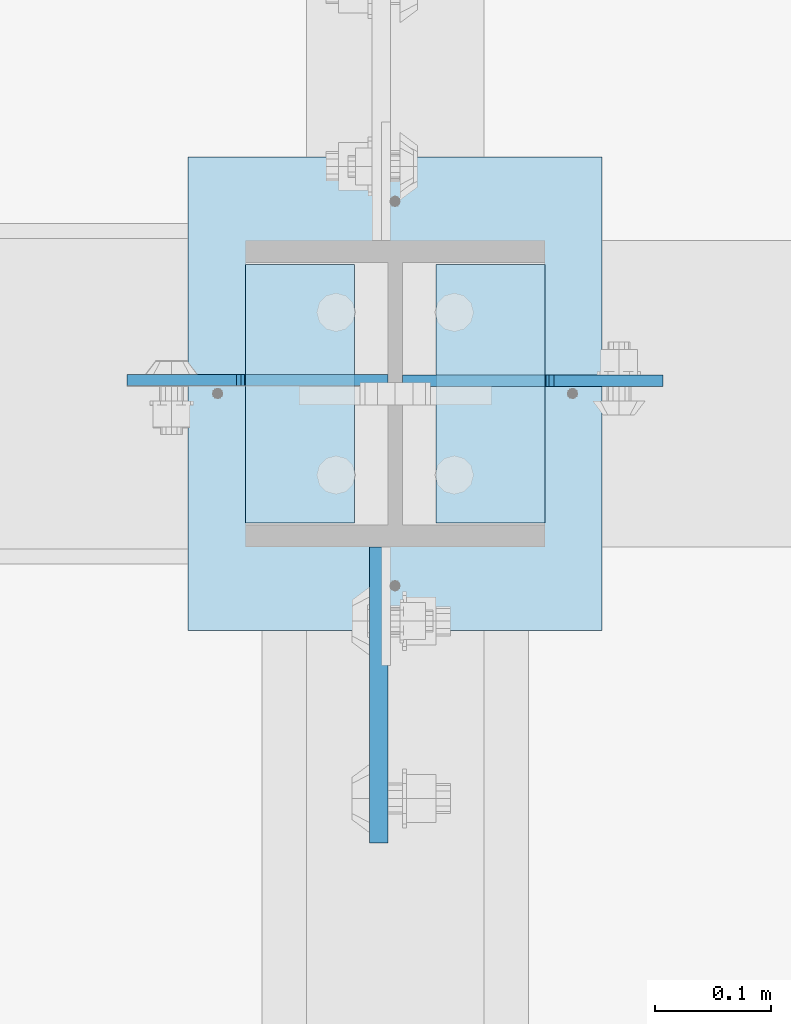
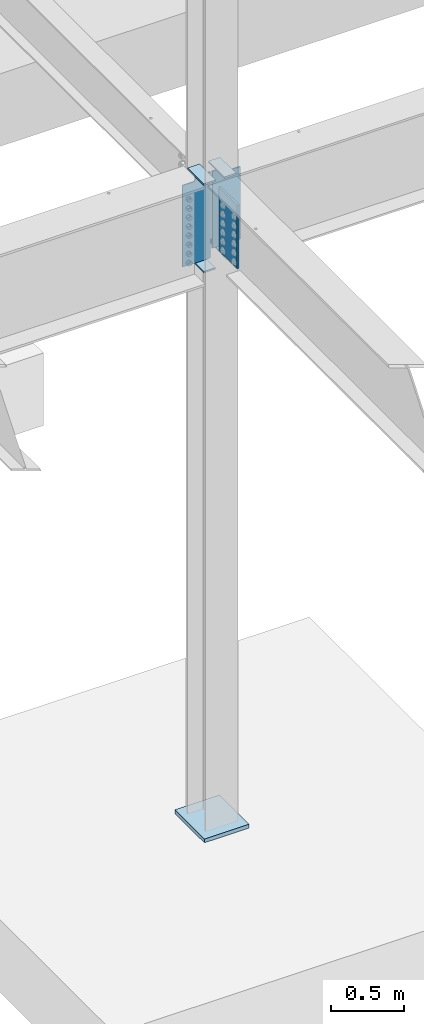
# One storey, part 1530 of 1763: 8 plates, 1 element without a shape of its own.
"""IFC2X3 building model written with IfcOpenShell, lengths in millimetres."""

import ifcopenshell
import ifcopenshell.guid

model = None  # the IFC model being written
_history = None  # IfcOwnerHistory: only IFC2X3 demands one
_inside = {}  # id of a spatial element -> (the spatial element, [elements in it])
_under = {}  # id of a project, library or spatial element -> (it, [spatial elements below it])
_declared = {}  # id of a project -> (the project, [libraries it declares])
_typed = {}  # id of a type object -> (the type object, [elements of that type])
_made_of = {}  # id of a material, layer set ... -> (it, [elements and type objects made of it])


def new_model(schema):
    """Start an empty IFC model of exactly this schema.

    Asked for "IFC4X3", IfcOpenShell would pick the latest addendum, in which some entities
    have other attributes; the version numbers below select the first issue.
    IFC2X3 requires an IfcOwnerHistory on every rooted entity: one is made here for all.
    """
    global model, _history
    if schema == "IFC4X3":
        model = ifcopenshell.file(schema_version=(4, 3, 0, 0))
    else:
        model = ifcopenshell.file(schema=schema)
    _inside.clear()
    _under.clear()
    _declared.clear()
    _typed.clear()
    _made_of.clear()
    _history = None
    if model.schema == "IFC2X3":
        org = make("IfcOrganization", Name="unknown")
        user = make(
            "IfcPersonAndOrganization",
            ThePerson=make("IfcPerson", FamilyName="unknown"),
            TheOrganization=org,
        )
        app = make(
            "IfcApplication",
            ApplicationDeveloper=org,
            Version="unknown",
            ApplicationFullName="unknown",
            ApplicationIdentifier="unknown",
        )
        _history = make(
            "IfcOwnerHistory",
            OwningUser=user,
            OwningApplication=app,
            ChangeAction="ADDED",
            CreationDate=0,
        )
    return model


def make(cls, **values):
    """One entity of the class cls with the attributes given. An attribute that is None is left unset."""
    return model.create_entity(
        cls, **{name: value for name, value in values.items() if value is not None}
    )


def rooted(cls, **values):
    """An entity with a GlobalId (a new one), such as an element, a storey or a relation."""
    return make(cls, GlobalId=ifcopenshell.guid.new(), OwnerHistory=_history, **values)


def si_unit(unit_type, name, prefix=None):
    """IfcSIUnit, for example si_unit("LENGTHUNIT", "METRE", prefix="MILLI")."""
    return make("IfcSIUnit", UnitType=unit_type, Prefix=prefix, Name=name)


def assignment(units):
    """IfcUnitAssignment: the units of a project."""
    return None if units is None else make("IfcUnitAssignment", Units=units)


def point(xyz):
    """IfcCartesianPoint."""
    return None if xyz is None else make("IfcCartesianPoint", Coordinates=xyz)


def direction(xyz):
    """IfcDirection."""
    return None if xyz is None else make("IfcDirection", DirectionRatios=xyz)


def frame(location, z_axis=None, x_axis=None):
    """IfcAxis2Placement3D, a coordinate frame: its origin and axes. An axis left out is left unset."""
    return make(
        "IfcAxis2Placement3D",
        Location=point(location),
        Axis=direction(z_axis),
        RefDirection=direction(x_axis),
    )


def origin_with_axes():
    """The frame at (0, 0, 0) with the z axis (0, 0, 1) and the x axis (1, 0, 0) written out."""
    return frame((0.0, 0.0, 0.0), z_axis=(0.0, 0.0, 1.0), x_axis=(1.0, 0.0, 0.0))


def place(relative_to, where):
    """IfcLocalPlacement: puts the frame where relative to a parent placement (None: the world)."""
    return make(
        "IfcLocalPlacement", PlacementRelTo=relative_to, RelativePlacement=where
    )


def context(
    kind, dimensions, precision=None, world=None, true_north=None, identifier=None
):
    """IfcGeometricRepresentationContext, for example the 3D "Model" context."""
    return make(
        "IfcGeometricRepresentationContext",
        ContextIdentifier=identifier,
        ContextType=kind,
        CoordinateSpaceDimension=dimensions,
        Precision=precision,
        WorldCoordinateSystem=world,
        TrueNorth=true_north,
    )


def subcontext(parent, identifier, kind, view, scale=None):
    """IfcGeometricRepresentationSubContext, for example "Body" below "Model"."""
    return make(
        "IfcGeometricRepresentationSubContext",
        ContextIdentifier=identifier,
        ContextType=kind,
        ParentContext=parent,
        TargetScale=scale,
        TargetView=view,
    )


def project(units=None, contexts=None):
    """IfcProject with its units and contexts."""
    return rooted(
        "IfcProject",
        Name="project",
        RepresentationContexts=contexts,
        UnitsInContext=assignment(units),
    )


def spatial(cls, under=None, at=None, **own):
    """A site, building, storey or space (cls), placed at a placement, below another one or the project."""
    s = rooted(cls, ObjectPlacement=at, **own)
    if under is not None:
        _under.setdefault(under.id(), (under, []))[1].append(s)
    return s


def faces_of(points, faces, orient=None, outer=None):
    """IfcFace entities. A face is a list of loops; a loop is a list of indices into points, from 0.

    orient and outer hold one flag for each loop. By default every Orientation is true, the
    first loop of a face is its IfcFaceOuterBound and the others are IfcFaceBound.
    """
    made = []
    for i, loops in enumerate(faces):
        bounds = []
        for j, loop in enumerate(loops):
            is_outer = j == 0 if outer is None else outer[i][j]
            bounds.append(
                make(
                    "IfcFaceOuterBound" if is_outer else "IfcFaceBound",
                    Bound=make("IfcPolyLoop", Polygon=[points[k] for k in loop]),
                    Orientation=True if orient is None else orient[i][j],
                )
            )
        made.append(make("IfcFace", Bounds=bounds))
    return made


def faceted_brep(points, faces, orient=None, outer=None, voids=None):
    """IfcFacetedBrep: a solid bounded by flat faces; with voids (closed shells), ...WithVoids."""
    shared = [point(p) for p in points]
    hull = make("IfcClosedShell", CfsFaces=faces_of(shared, faces, orient, outer))
    if voids is None:
        return make("IfcFacetedBrep", Outer=hull)
    return make(
        "IfcFacetedBrepWithVoids",
        Outer=hull,
        Voids=[
            make(cls, CfsFaces=faces_of(shared, fs, o, b)) for cls, fs, o, b in voids
        ],
    )


def shape(context_of_items, identifier, shape_type, items):
    """IfcShapeRepresentation: the items that make up one representation, for example the "Body"."""
    return make(
        "IfcShapeRepresentation",
        ContextOfItems=context_of_items,
        RepresentationIdentifier=identifier,
        RepresentationType=shape_type,
        Items=items,
    )


def material(Name=None, Category=None):
    """IfcMaterial."""
    return make("IfcMaterial", Name=Name, Category=Category)


def made_of(thing, what):
    """Note that an element or type object is made of a material, layer set ...; save() writes the relation."""
    if what is not None:
        _made_of.setdefault(what.id(), (what, []))[1].append(thing)
    return thing


def type_object(cls, material=None, **own):
    """A type object (cls), such as IfcWallType, which elements share."""
    return made_of(rooted(cls, **own), material)


def element(
    cls,
    number,
    at=None,
    inside=None,
    cuts=None,
    type_object=None,
    material=None,
    context=None,
    identifier="Body",
    shape_type=None,
    held_by="IfcProductDefinitionShape",
    body=None,
    shapes=None,
    **own,
):
    """One element of the class cls, such as IfcWall. Its Tag is "e" and its number.

    at: its placement. inside: the storey or other place that contains it. cuts: it is an
    opening in that element (IfcRelVoidsElement). A single representation is given by context,
    identifier, shape_type and body (its items); several are given by shapes. held_by: the class
    of the entity that holds the representations. save() writes the other relations.
    """
    e = rooted(cls, Tag="e%d" % number, ObjectPlacement=at, **own)
    if body is not None:
        shapes = [shape(context, identifier, shape_type, body)]
    if shapes is not None:
        e.Representation = make(held_by, Representations=shapes)
    if inside is not None:
        _inside.setdefault(inside.id(), (inside, []))[1].append(e)
    if cuts is not None:
        rooted(
            "IfcRelVoidsElement", RelatingBuildingElement=cuts, RelatedOpeningElement=e
        )
    if type_object is not None:
        _typed.setdefault(type_object.id(), (type_object, []))[1].append(e)
    return made_of(e, material)


def aggregate(whole, parts):
    """IfcRelAggregates: a whole, such as a stair, and the parts it consists of."""
    return rooted("IfcRelAggregates", RelatingObject=whole, RelatedObjects=parts)


def save(model, path):
    """Write the relations noted so far, then the file.

    IfcRelAggregates (storeys below a building ...), IfcRelContainedInSpatialStructure (elements
    in a storey), IfcRelDefinesByType, IfcRelAssociatesMaterial and IfcRelDeclares: one each for
    every whole, place, type object, material and project.
    """
    for whole, parts in _under.values():
        aggregate(whole, parts)
    for where, things in _inside.values():
        rooted(
            "IfcRelContainedInSpatialStructure",
            RelatedElements=things,
            RelatingStructure=where,
        )
    for kind, things in _typed.values():
        rooted("IfcRelDefinesByType", RelatedObjects=things, RelatingType=kind)
    for what, things in _made_of.values():
        rooted("IfcRelAssociatesMaterial", RelatedObjects=things, RelatingMaterial=what)
    for by, libraries in _declared.values():
        rooted("IfcRelDeclares", RelatingContext=by, RelatedDefinitions=libraries)
    model.write(path)


model = new_model("IFC2X3")

# Units and contexts
model_context = context("Model", 3, precision=1e-05, world=origin_with_axes())
body_context = subcontext(model_context, "Body", "Model", "MODEL_VIEW")
ifc_project = project(units=[si_unit("LENGTHUNIT", "METRE", prefix="MILLI"), si_unit("AREAUNIT", "SQUARE_METRE"), si_unit("VOLUMEUNIT", "CUBIC_METRE"), si_unit("MASSUNIT", "GRAM", prefix="KILO"), si_unit("TIMEUNIT", "SECOND"), si_unit("PLANEANGLEUNIT", "RADIAN"), si_unit("SOLIDANGLEUNIT", "STERADIAN"), si_unit("THERMODYNAMICTEMPERATUREUNIT", "DEGREE_CELSIUS"), si_unit("LUMINOUSINTENSITYUNIT", "LUMEN")], contexts=[model_context])

# Site, building, storey
site_placement = place(None, origin_with_axes())
site = spatial("IfcSite", under=ifc_project, at=site_placement, CompositionType="ELEMENT")
building_placement = place(site_placement, origin_with_axes())
building = spatial("IfcBuilding", under=site, at=building_placement, Name="Undefined", CompositionType="ELEMENT")
storey_placement = place(building_placement, origin_with_axes())
storey = spatial("IfcBuildingStorey", under=building, at=storey_placement, Name="Undefined", CompositionType="ELEMENT", Elevation=0.0)

# Assembly, plates
assembly_placement = place(storey_placement, origin_with_axes())
assembly = element("IfcElementAssembly", 1, at=assembly_placement, inside=storey, Name="COLUMN", AssemblyPlace="NOTDEFINED", PredefinedType="RIGID_FRAME")
ifc_material_1 = material(Name="STEEL/A36")
plate_type_1 = type_object("IfcPlateType", PredefinedType="NOTDEFINED")
plate_1_placement = place(assembly_placement, frame((-72619.6247736983, 44916.725, 4451.34997558594), z_axis=(0.0, -1.0, 0.0), x_axis=(1.0, 0.0, 0.0)))
plate_1 = element("IfcPlate", 2, at=plate_1_placement, type_object=plate_type_1, material=ifc_material_1, Name="PLATE", context=body_context, shape_type="Brep", body=[
    faceted_brep([(0.0, -6.34999999999491, 1.45519152283669e-11), (0.0, -6.35000000000036, 222.25), (0.0, 6.35000000000036, 222.25), (0.0, 6.34999999999491, -2.91038304567337e-11), (93.6624984741211, -6.35000000000036, 222.25), (93.6624984741211, 6.35000000000036, 222.25), (93.6624984741211, -6.35000000000036, 0.0), (93.6624984741211, 6.35000000000036, 0.0)], [[[0, 1, 2, 3]], [[1, 4, 5, 2]], [[4, 6, 7, 5]], [[6, 0, 3, 7]], [[5, 7, 3, 2]], [[6, 4, 1, 0]]]),
])
plate_2_placement = place(assembly_placement, frame((-72619.6247736983, 44916.725, 5187.95), z_axis=(0.0, -1.0, 0.0), x_axis=(1.0, 0.0, 0.0)))
plate_2 = element("IfcPlate", 3, at=plate_2_placement, type_object=plate_type_1, material=ifc_material_1, Name="PLATE", context=body_context, shape_type="Brep", body=[
    faceted_brep([(0.0, -6.34999999999491, 1.45519152283669e-11), (0.0, -6.35000000000036, 222.25), (0.0, 6.35000000000036, 222.25), (0.0, 6.34999999999491, -2.91038304567337e-11), (93.6624984741211, -6.35000000000036, 222.25), (93.6624984741211, 6.35000000000036, 222.25), (93.6624984741211, -6.35000000000036, 0.0), (93.6624984741211, 6.35000000000036, 0.0)], [[[0, 1, 2, 3]], [[1, 4, 5, 2]], [[4, 6, 7, 5]], [[6, 0, 3, 7]], [[5, 7, 3, 2]], [[6, 4, 1, 0]]]),
])
plate_3_placement = place(assembly_placement, frame((-72362.4497736983, 44694.475, 4527.54998779297), z_axis=(0.0, 1.0, 0.0), x_axis=(-1.0, 0.0, 0.0)))
plate_3 = element("IfcPlate", 4, at=plate_3_placement, type_object=plate_type_1, material=ifc_material_1, Name="PLATE", context=body_context, shape_type="Brep", body=[
    faceted_brep([(0.0, -6.34999999999491, 1.45519152283669e-11), (0.0, -6.35000000000036, 222.25), (0.0, 6.35000000000036, 222.25), (0.0, 6.34999999999491, -2.91038304567337e-11), (93.6624984741211, -6.35000000000036, 222.25), (93.6624984741211, 6.35000000000036, 222.25), (93.6624984741211, -6.35000000000036, 0.0), (93.6624984741211, 6.35000000000036, 0.0)], [[[0, 1, 2, 3]], [[1, 4, 5, 2]], [[4, 6, 7, 5]], [[6, 0, 3, 7]], [[5, 7, 3, 2]], [[6, 4, 1, 0]]]),
])
plate_4_placement = place(assembly_placement, frame((-72362.4497736983, 44694.475, 5187.95), z_axis=(0.0, 1.0, 0.0), x_axis=(-1.0, 0.0, 0.0)))
plate_4 = element("IfcPlate", 5, at=plate_4_placement, type_object=plate_type_1, material=ifc_material_1, Name="PLATE", context=body_context, shape_type="Brep", body=[
    faceted_brep([(0.0, -6.34999999999491, 1.45519152283669e-11), (0.0, -6.35000000000036, 222.25), (0.0, 6.35000000000036, 222.25), (0.0, 6.34999999999491, -2.91038304567337e-11), (93.6624984741211, -6.35000000000036, 222.25), (93.6624984741211, 6.35000000000036, 222.25), (93.6624984741211, -6.35000000000036, 0.0), (93.6624984741211, 6.35000000000036, 0.0)], [[[0, 1, 2, 3]], [[1, 4, 5, 2]], [[4, 6, 7, 5]], [[6, 0, 3, 7]], [[5, 7, 3, 2]], [[6, 4, 1, 0]]]),
])
ifc_material_2 = material(Name="STEEL/A572-50")
plate_type_2 = type_object("IfcPlateType", PredefinedType="NOTDEFINED")
plate_5_placement = place(assembly_placement, frame((-72505.3247736984, 44673.8375, 5143.5), z_axis=(0.0, -1.0, 0.0), x_axis=(0.0, 0.0, -1.0)))
plate_5 = element("IfcPlate", 6, at=plate_5_placement, type_object=plate_type_2, material=ifc_material_2, Name="PLATE", context=body_context, shape_type="Brep", body=[
    faceted_brep([(-7.27595761418343e-12, -7.9375, 0.0), (0.0, -7.9375, 254.0), (0.0, 7.9375, 254.0), (-7.27595761418343e-12, 7.9375, 0.0), (533.400024414062, -7.9375, 254.0), (533.400024414062, 7.9375, 254.0), (533.400024414062, -7.9375, 0.0), (533.400024414062, 7.9375, 0.0)], [[[0, 1, 2, 3]], [[1, 4, 5, 2]], [[4, 6, 7, 5]], [[6, 0, 3, 7]], [[5, 7, 3, 2]], [[6, 4, 1, 0]]]),
])
plate_type_3 = type_object("IfcPlateType", PredefinedType="NOTDEFINED")
plate_6_placement = place(assembly_placement, frame((-72497.3872736983, 44817.50625, 5181.6), z_axis=(-1.0, 0.0, 0.0), x_axis=(0.0, 0.0, -1.0)))
plate_6 = element("IfcPlate", 7, at=plate_6_placement, type_object=plate_type_3, material=ifc_material_1, Name="PLATE", context=body_context, shape_type="Brep", body=[
    faceted_brep([(25.4000001907334, -4.76250000000073, 122.237503051758), (25.4000001907334, 4.76250000000073, 122.237503051758), (-2.5465851649642e-11, 4.76250000019581, 122.237500000236), (-3.45607986673713e-11, -4.76249999983202, 122.23750000025), (30.2600797087798, -4.76250000000073, 123.204232974349), (30.2600797087798, 4.76250000000073, 123.204232974349), (34.3802561769335, -4.76250000000073, 125.957246874823), (34.3802561769335, 4.76250000000073, 125.957246874823), (37.133270077411, -4.76250000000073, 130.077423342977), (37.133270077411, 4.76250000000073, 130.077423342977), (38.0999999999985, -4.76250000000073, 134.937502861023), (38.0999999999985, 4.76250000000073, 134.937502861023), (38.0999999999985, -4.76250000000073, 223.837493896484), (38.0999999999985, 4.76250000000073, 223.837493896484), (723.900024414062, -4.76250000000073, 0.0), (0.0, -4.76249999999982, 0.0), (0.0, 4.76249999999982, 0.0), (723.900024414062, 4.76250000000073, 0.0), (723.900024414062, -4.76250000000073, 223.837493896484), (723.900024414062, 4.76250000000073, 223.837493896484)], [[[0, 1, 2, 3]], [[4, 5, 1, 0]], [[6, 7, 5, 4]], [[8, 9, 7, 6]], [[10, 11, 9, 8]], [[12, 13, 11, 10]], [[14, 15, 16, 17]], [[18, 14, 17, 19]], [[8, 6, 4, 0, 3, 15, 14, 18, 12, 10]], [[16, 15, 3, 2]], [[19, 17, 16, 2, 1, 5, 7, 9, 11, 13]], [[18, 19, 13, 12]]]),
])
plate_7_placement = place(assembly_placement, frame((-72484.6872736983, 44816.7125, 5181.6), z_axis=(1.0, 0.0, 0.0), x_axis=(0.0, 0.0, -1.0)))
plate_7 = element("IfcPlate", 8, at=plate_7_placement, type_object=plate_type_3, material=ifc_material_1, Name="PLATE", context=body_context, shape_type="Brep", body=[
    faceted_brep([(25.4000001907334, -4.76250000000073, 122.237503051758), (25.4000001907334, 4.76250000000073, 122.237503051758), (-2.5465851649642e-11, 4.76250000019581, 122.237500000236), (-3.45607986673713e-11, -4.76249999983202, 122.23750000025), (30.2600797087798, -4.76250000000073, 123.204232974349), (30.2600797087798, 4.76250000000073, 123.204232974349), (34.3802561769335, -4.76250000000073, 125.957246874823), (34.3802561769335, 4.76250000000073, 125.957246874823), (37.133270077411, -4.76250000000073, 130.077423342977), (37.133270077411, 4.76250000000073, 130.077423342977), (38.0999999999985, -4.76250000000073, 134.937502861023), (38.0999999999985, 4.76250000000073, 134.937502861023), (38.0999999999985, -4.76250000000073, 223.837493896484), (38.0999999999985, 4.76250000000073, 223.837493896484), (647.700012207031, -4.76250000000073, 0.0), (0.0, -4.76249999999982, 0.0), (0.0, 4.76249999999982, 0.0), (647.700012207031, 4.76250000000073, 0.0), (647.700012207031, -4.76250000000073, 223.837493896484), (647.700012207031, 4.76250000000073, 223.837493896484)], [[[0, 1, 2, 3]], [[4, 5, 1, 0]], [[6, 7, 5, 4]], [[8, 9, 7, 6]], [[10, 11, 9, 8]], [[12, 13, 11, 10]], [[14, 15, 16, 17]], [[18, 14, 17, 19]], [[8, 6, 4, 0, 3, 15, 14, 18, 12, 10]], [[16, 15, 3, 2]], [[19, 17, 16, 2, 1, 5, 7, 9, 11, 13]], [[18, 19, 13, 12]]]),
])
plate_type_4 = type_object("IfcPlateType", PredefinedType="NOTDEFINED")
plate_8_placement = place(assembly_placement, frame((-72668.8372736983, 45008.8, -250.824999999996), z_axis=(1.0, 0.0, 0.0), x_axis=(0.0, -1.0, 0.0)))
plate_8 = element("IfcPlate", 9, at=plate_8_placement, type_object=plate_type_4, material=ifc_material_1, Name="PLATE", context=body_context, shape_type="Brep", body=[
    faceted_brep([(0.0, -15.875, 0.0), (0.0, -15.875, 355.600006103516), (0.0, 15.875, 355.600006103516), (0.0, 15.875, 0.0), (406.399993896484, -15.875, 355.600006103516), (406.399993896484, 15.875, 355.600006103516), (406.399993896484, -15.875, 0.0), (406.399993896484, 15.875, 0.0)], [[[0, 1, 2, 3]], [[1, 4, 5, 2]], [[4, 6, 7, 5]], [[6, 0, 3, 7]], [[5, 7, 3, 2]], [[6, 4, 1, 0]]]),
])
aggregate(assembly, [plate_1, plate_2, plate_6, plate_3, plate_4, plate_7, plate_5, plate_8])

save(model, "model.ifc")
